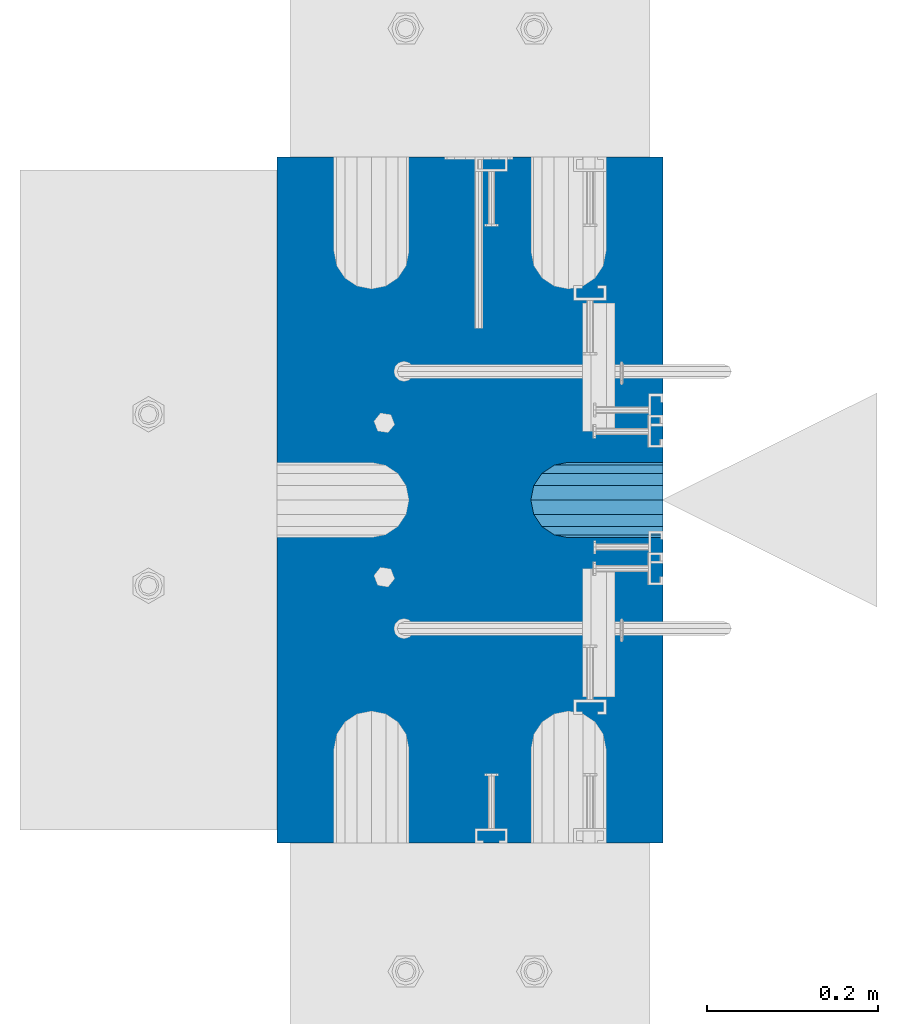
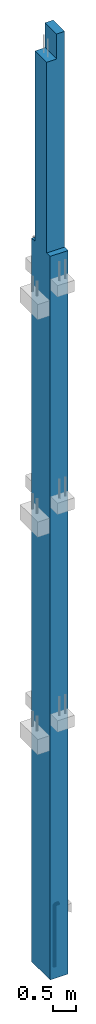
# One storey, part 2 of 41: 1 beam, 1 column, 2 elements without a shape of their own.
"""IFC2X3 building model written with IfcOpenShell, lengths in millimetres."""

from ifc_helpers import new_model, si_unit, frame, origin_with_axes, place, context, subcontext, project, spatial, faceted_brep, material, type_object, element, aggregate, save


model = new_model("IFC2X3")

# Units and contexts
model_context = context("Model", 3, precision=1e-05, world=origin_with_axes())
body_context = subcontext(model_context, "Body", "Model", "MODEL_VIEW")
ifc_project = project(units=[si_unit("LENGTHUNIT", "METRE", prefix="MILLI"), si_unit("AREAUNIT", "SQUARE_METRE"), si_unit("VOLUMEUNIT", "CUBIC_METRE"), si_unit("MASSUNIT", "GRAM", prefix="KILO"), si_unit("TIMEUNIT", "SECOND"), si_unit("PLANEANGLEUNIT", "RADIAN"), si_unit("SOLIDANGLEUNIT", "STERADIAN"), si_unit("THERMODYNAMICTEMPERATUREUNIT", "DEGREE_CELSIUS"), si_unit("LUMINOUSINTENSITYUNIT", "LUMEN")], contexts=[model_context])

# Site, building, storey
site_placement = place(None, frame((-177556.685383467, -198018.589999756, 1290.0), z_axis=(0.0, 0.0, 1.0), x_axis=(0.788225611989142, -0.615386370180835, 0.0)))
site = spatial("IfcSite", under=ifc_project, at=site_placement, CompositionType="ELEMENT")
building_placement = place(site_placement, origin_with_axes())
building = spatial("IfcBuilding", under=site, at=building_placement, Name="Undefined", CompositionType="ELEMENT")
storey_placement = place(building_placement, origin_with_axes())
storey = spatial("IfcBuildingStorey", under=building, at=storey_placement, Name="Undefined", CompositionType="ELEMENT", Elevation=0.0)

# Assemblies, column, beam
assembly_1_placement = place(storey_placement, origin_with_axes())
assembly_1 = element("IfcElementAssembly", 1, at=assembly_1_placement, inside=storey, AssemblyPlace="NOTDEFINED", PredefinedType="REINFORCEMENT_UNIT")
ifc_material_1 = material(Name="CONCRETE/C50/60")
column_type = type_object("IfcColumnType", PredefinedType="NOTDEFINED")
column_placement = place(assembly_1_placement, frame((18096.7856708698, 265349.288407257, -1290.0), z_axis=(-0.788225611989142, -0.615386370180835, 0.0), x_axis=(0.0, 0.0, 1.0)))
column = element("IfcColumn", 2, at=column_placement, type_object=column_type, material=ifc_material_1, context=body_context, shape_type="Brep", body=[
    faceted_brep([(24210.0, -250.000000288157, 225.00000024747), (24210.0, -250.000000288797, -24.9999997523264), (24210.0, 249.99999971097, -24.9999997548875), (24210.0, 249.999999711639, 225.000000244938), (24870.0, -250.000000288797, -24.9999997523264), (24870.0, 249.99999971097, -24.9999997548875), (19160.0, -400.000000288099, 225.000000248256), (19160.0, -400.000000289263, -224.999999751424), (19160.0, -250.000000289321, -224.999999752152), (19160.0, -250.000000288157, 225.00000024747), (0.0, -400.000000329339, 225.000000121712), (0.0, -400.000000330474, -224.999999877968), (0.0, 399.999999670341, 225.000000117609), (0.0, 399.999999669206, -224.999999882071), (19160.0, 399.999999711552, 225.000000244181), (19160.0, 399.999999710388, -224.999999755499), (19160.0, 249.999999711639, 225.000000244938), (19160.0, 249.999999710475, -224.999999754713), (24870.0, -250.000000289321, -224.999999752152), (24870.0, 249.999999710475, -224.999999754713)], [[[0, 1, 2, 3]], [[4, 5, 2, 1]], [[6, 7, 8, 9]], [[10, 11, 7, 6]], [[11, 10, 12, 13]], [[13, 12, 14, 15]], [[16, 17, 15, 14]], [[18, 8, 7, 11, 13, 15, 17, 19]], [[0, 9, 8, 18, 4, 1]], [[16, 14, 12, 10, 6, 9, 0, 3]], [[19, 17, 16, 3, 2, 5]], [[18, 19, 5, 4]]]),
])
assembly_2_placement = place(assembly_1_placement, origin_with_axes())
assembly_2 = element("IfcElementAssembly", 3, at=assembly_2_placement, AssemblyPlace="NOTDEFINED", PredefinedType="RIGID_FRAME")
aggregate(assembly_1, [assembly_2, column])
ifc_material_2 = material(Name="STEEL/NEG_BETON")
beam_type = type_object("IfcBeamType", PredefinedType="NOTDEFINED")
beam_placement = place(assembly_2_placement, frame((18187.4316162484, 265420.057839827, -1290.0), z_axis=(0.615386370178831, -0.788225611990706, 0.0), x_axis=(0.0, 0.0, 1.0)))
beam = element("IfcBeam", 4, at=beam_placement, type_object=beam_type, material=ifc_material_2, context=body_context, shape_type="Brep", body=[
    faceted_brep([(0.0, -43.999999753345, 2.88331648334861e-07), (0.0, -40.6506991838105, -16.8380707357428), (1590.0, -40.6506991838105, -16.8380707357428), (1589.99999999999, -43.999999753345, 2.88331648334861e-07), (0.0, -31.1126981254783, -31.1126980838017), (1590.0, -31.1126981254783, -31.1126980838017), (0.0, -16.8380707773322, -40.6506991419883), (1590.0, -16.8380707773322, -40.6506991419883), (0.0, 2.46742274612188e-07, -43.9999997114064), (1590.0, 2.46742274612188e-07, -43.9999997114064), (0.0, 16.8380712707876, -40.6506991418137), (1590.0, 16.8380712707876, -40.6506991418137), (0.0, 31.1126986189047, -31.1126980834524), (1590.0, 31.1126986189047, -31.1126980834524), (0.0, 40.6506996771204, -16.8380707352771), (1590.0, 40.6506996771204, -16.8380707352771), (0.0, 44.0000002465677, 2.88768205791712e-07), (1590.0, 44.0000002465677, 2.88768205791712e-07), (0.0, 40.6506996770622, 16.8380713128427), (1590.0, 40.6506996770622, 16.8380713128427), (0.0, 31.1126986187301, 31.1126986609306), (1590.0, 31.1126986187301, 31.1126986609306), (0.0, 16.8380712705839, 40.6506997191464), (1590.0, 16.8380712705839, 40.6506997191464), (0.0, 2.46509443968534e-07, 44.0000002885354), (1590.0, 2.46509443968534e-07, 44.0000002885354), (0.0, -16.8380707775359, 40.6506997189426), (1590.0, -16.8380707775359, 40.6506997189426), (0.0, -31.1126981256821, 31.1126986605814), (1590.0, -31.1126981256821, 31.1126986605814), (0.0, -40.6506991838978, 16.838071312377), (1590.0, -40.6506991838978, 16.838071312377), (4.47878846898675e-07, -40.0000000634464, 0.0), (4.47878846898675e-07, -36.9551813638827, 15.3073372946019), (1590.0, -36.9551810538396, 15.3073375829845), (1589.99999999999, -39.999999753345, 2.88360752165318e-07), (4.47937054559588e-07, -28.2842713108694, 28.284271247463), (1590.0, -28.2842710008845, 28.2842715359002), (4.4800981413573e-07, -15.3073373580119, 36.9551813004509), (1590.0, -15.3073370480561, 36.9551815889135), (4.48068021796644e-07, -6.34463503956795e-08, 40.0), (1590.0, 2.46538547798991e-07, 40.0000002885645), (4.48140781372786e-07, 15.3073372311774, 36.9551813004509), (1590.0, 15.3073375411332, 36.9551815890882), (4.48213540948927e-07, 28.2842711840058, 28.284271247463), (1590.0, 28.2842714939907, 28.2842715361621), (4.48271748609841e-07, 36.95518123699, 15.3073372946019), (1590.0, 36.9551815469749, 15.3073375833046), (4.48286300525069e-07, 39.9999999365536, 0.0), (1590.0, 40.0000002465677, 2.88768205791712e-07), (4.48271748609841e-07, 36.95518123699, -15.3073372946019), (1590.0, 36.9551815470913, -15.3073370058555), (4.48213540948927e-07, 28.2842711840058, -28.284271247463), (1590.0, 28.2842714941071, -28.2842709587712), (4.48140781372786e-07, 15.3073372311774, -36.9551813004509), (1590.0, 15.3073375413369, -36.9551810117846), (4.48068021796644e-07, -6.34463503956795e-08, -40.0), (1590.0, 2.46742274612188e-07, -39.9999997114064), (4.4800981413573e-07, -15.3073373580119, -36.9551813004509), (1590.0, -15.3073370479106, -36.9551810119592), (4.47937054559588e-07, -28.2842713108694, -28.284271247463), (1590.0, -28.284271000739, -28.2842709590332), (4.47878846898675e-07, -36.9551813638827, -15.3073372946019), (1590.0, -36.9551810537523, -15.3073370062048), (1591.55291427061, -44.204444795876, 2.88884621113539e-07), (1592.41977704577, -40.969268875866, 16.83807131293), (1594.88839337186, -31.7562673225475, 31.1126986611343), (1598.5829387913, -17.9680361063511, 40.6506997194665), (1602.94095225512, -1.70370843930868, 44.0000002890592), (1607.29896571893, 14.5606192276464, 40.650699719612), (1610.99351113838, 28.3488504439301, 31.1126986614254), (1613.46212746447, 37.5618519973068, 16.8380713133374), (1614.32899023963, 40.7970279174624, 2.89292074739933e-07), (1613.46212746447, 37.5618519973941, -16.8380707347824), (1610.99351113838, 28.3488504441048, -31.1126980829576), (1607.29896571893, 14.5606192278792, -40.650699141348), (1602.94095225512, -1.70370843910496, -43.9999997109117), (1598.5829387913, -17.9680361061473, -40.6506991414644), (1594.88839337186, -31.7562673223438, -31.1126980832487), (1592.41977704577, -40.9692688757787, -16.8380707351898), (1613.29371405922, 36.9333246122987, 2.89292074739933e-07), (1612.50565699089, 33.9922555939993, 15.3073375838285), (1610.26146033081, 25.6167996363656, 28.2842715366569), (1606.90278267677, 13.082043985225, 36.9551815895829), (1602.94095225512, -1.70370843933779, 40.0000002890883), (1598.97912183347, -16.4894608639006, 36.9551815894083), (1595.62044417943, -29.024216514983, 28.2842715363658), (1593.37624751934, -37.3996724725293, 15.3073375835083), (1592.58819045102, -40.3407414907415, 2.88913724943995e-07), (1593.37624751934, -37.3996724724711, -15.30733700571), (1595.62044417943, -29.0242165148375, -28.2842709585093), (1598.97912183347, -16.489460863726, -36.9551810114353), (1602.94095225512, -1.70370843910496, -39.9999997108825), (1606.90278267677, 13.0820439854288, -36.9551810112898), (1610.26146033081, 25.6167996365111, -28.2842709582183), (1612.50565699089, 33.9922555940866, -15.3073370053316), (1630.55634918609, 20.2456576060504, 31.1126986613672), (1635.32534971523, 28.5058088238875, 16.8380713132792), (1623.41903551202, 7.88346769296913, 40.6506997195829), (1614.99999999998, -6.6987295645813, 44.0000002890592), (1606.58096448795, -21.2809268221026, 40.6506997194665), (1599.44365081388, -33.6431167351257, 31.1126986611052), (1594.67465028474, -41.9032679528755, 16.83807131293), (1592.99999999999, -44.8038473309425, 2.88884621113539e-07), (1594.67465028474, -41.9032679528173, -16.8380707351898), (1599.44365081388, -33.6431167349801, -31.1126980832778), (1606.58096448795, -21.2809268218698, -40.6506991414935), (1614.99999999998, -6.69872956431936, -43.9999997108825), (1623.41903551202, 7.88346769317286, -40.6506991413771), (1630.55634918609, 20.245657606225, -31.1126980830159), (1635.32534971523, 28.5058088239748, -16.8380707348406), (1636.99999999998, 31.4063882019836, 2.89204763248563e-07), (1633.47759065021, 25.3053962432023, -15.307337005419), (1634.99999999998, 27.9422865869128, 2.89262970909476e-07), (1629.14213562371, 17.7961678634456, -28.2842709582474), (1622.65366864729, 6.55781339702662, -36.9551810113189), (1614.99999999998, -6.69872956431936, -39.9999997109117), (1607.34633135268, -19.9552725257818, -36.9551810114644), (1600.85786437626, -31.1936269922007, -28.2842709585384), (1596.52240934976, -38.7028553720447, -15.30733700571), (1594.99999999999, -41.3397457158135, 2.88884621113539e-07), (1596.52240934976, -38.7028553721029, 15.3073375835083), (1600.85786437626, -31.1936269923463, 28.2842715363658), (1607.34633135268, -19.9552725259855, 36.9551815894083), (1614.99999999998, -6.6987295645522, 40.0000002890592), (1622.65366864729, 6.5578133968811, 36.9551815895829), (1629.14213562371, 17.796167863271, 28.2842715366278), (1633.47759065021, 25.305396243115, 15.3073375837994), (1647.35533905931, 7.35533930556267, 31.1126986613381), (1654.09972428659, 14.0997245328326, 16.8380713131919), (1637.26165326253, -2.73834649124183, 40.6506997195538), (1625.35533905931, -14.6446606944664, 44.000000289001), (1613.4490248561, -26.5509748976619, 40.6506997194374), (1603.35533905931, -36.6446606944373, 31.1126986610761), (1596.61095383203, -43.3890459216491, 16.83807131293), (1594.24264068711, -45.7573590665124, 2.88855517283082e-07), (1596.61095383203, -43.3890459215909, -16.8380707352189), (1603.35533905931, -36.6446606942627, -31.1126980833069), (1613.4490248561, -26.5509748974582, -40.6506991415517), (1625.35533905931, -14.6446606942336, -43.9999997109699), (1637.26165326253, -2.7383464910381, -40.6506991414062), (1647.35533905931, 7.35533930567908, -31.1126980831032), (1654.09972428659, 14.099724532949, -16.8380707348988), (1656.46803743151, 16.4680376778415, 2.89175659418106e-07), (1651.48659835683, 11.4865986031655, -15.3073370054772), (1653.63961030677, 13.6396105530439, 2.89146555587649e-07), (1645.35533905931, 5.35533930567908, -28.2842709583347), (1636.17926106223, -3.82073869134183, -36.9551810113771), (1625.35533905931, -14.6446606942336, -39.9999997109699), (1614.53141705639, -25.4685826971836, -36.9551810114644), (1605.35533905931, -34.6446606942627, -28.2842709585675), (1599.22407976179, -40.7759199918073, -15.3073370057391), (1597.07106781185, -42.9289319418021, 2.88826413452625e-07), (1599.22407976179, -40.7759199918946, 15.3073375834792), (1605.35533905931, -34.6446606944082, 28.284271536395), (1614.53141705639, -25.4685826973582, 36.9551815894083), (1625.35533905931, -14.6446606944373, 40.000000289001), (1636.17926106223, -3.82073869154556, 36.9551815894956), (1645.35533905931, 5.35533930556267, 28.2842715365696), (1651.48659835683, 11.4865986031364, 15.3073375837412), (1660.24565735981, -9.44365056764218, 31.1126986612508), (1668.50580857761, -4.6746500384761, 16.8380713131337), (1647.88346744676, -16.5809642417589, 40.6506997194665), (1633.3012701892, -24.9999997537816, 44.0000002889428), (1618.71907293164, -33.4190352658043, 40.6506997193792), (1606.35688301859, -40.5563489398628, 31.112698661047), (1598.09673180079, -45.3253494689416, 16.8380713129009), (1595.19615242269, -46.9999997536361, 2.88855517283082e-07), (1598.09673180079, -45.3253494688834, -16.8380707352189), (1606.35688301859, -40.5563489396882, -31.112698083336), (1618.71907293164, -33.4190352655714, -40.6506991415517), (1633.3012701892, -24.9999997535488, -43.9999997110281), (1647.88346744676, -16.5809642415552, -40.6506991414644), (1660.24565735981, -9.44365056749666, -31.1126980831614), (1668.50580857761, -4.67465003841789, -16.8380707349861), (1671.40638795571, -2.99999975369428, 2.89088347926736e-07), (1665.30539599684, -6.52240910343244, -15.3073370055354), (1667.94228634057, -4.99999975372339, 2.89030140265822e-07), (1657.79616761703, -10.8578641298518, -28.2842709583929), (1646.55781315062, -17.3463311062951, -36.9551810114644), (1633.3012701892, -24.9999997535488, -39.999999710999), (1620.04472722778, -32.6536684008606, -36.9551810115227), (1608.80637276137, -39.142135377333, -28.2842709585675), (1601.29714438156, -43.4775904038397, -15.30733700571), (1598.66025403783, -44.9999997536652, 2.88826413452625e-07), (1601.29714438156, -43.4775904038979, 15.3073375834501), (1608.80637276137, -39.1421353774786, 28.2842715363076), (1620.04472722778, -32.6536684010644, 36.9551815893792), (1633.3012701892, -24.9999997537816, 40.0000002889428), (1646.55781315062, -17.3463311064697, 36.9551815894374), (1657.79616761703, -10.8578641300264, 28.2842715364823), (1665.30539599684, -6.52240910349065, 15.3073375836248), (1668.34885019768, -29.006488615385, 31.1126986611052), (1677.56185175105, -26.5378722892492, 16.8380713130173), (1654.56061898146, -32.7010340348643, 40.6506997193792), (1638.29629131443, -37.0590474986238, 44.0000002888846), (1622.0319636474, -41.4170609624416, 40.6506997193792), (1608.24373243118, -45.1116063818336, 31.1126986610761), (1599.03073087781, -47.5802227078821, 16.83807131293), (1595.79555495772, -48.4470854829997, 2.88855517283082e-07), (1599.03073087781, -47.5802227078239, -16.8380707351898), (1608.24373243118, -45.111606381688, -31.112698083336), (1622.0319636474, -41.4170609622379, -40.6506991415808), (1638.29629131443, -37.0590474984201, -43.9999997110572), (1654.56061898146, -32.7010340346314, -40.6506991415808), (1668.34885019768, -29.0064886152395, -31.1126980832778), (1677.56185175105, -26.5378722891619, -16.8380707351025), (1680.79702767114, -25.6710095140443, 2.88913724943995e-07), (1673.99225534772, -27.4943427627441, -15.3073370056518), (1676.93332436598, -26.7062856944685, 2.88942828774452e-07), (1665.61679939011, -29.7385394227749, -28.2842709585093), (1653.082043739, -33.0972170768073, -36.9551810115518), (1638.29629131443, -37.0590474984201, -39.9999997110572), (1623.51053888986, -41.020877920062, -36.9551810115518), (1610.97578323875, -44.3795555741235, -28.2842709585675), (1602.60032728114, -46.6237522342417, -15.3073370057391), (1599.65925826287, -47.4118093026336, 2.88826413452625e-07), (1602.60032728114, -46.623752234329, 15.3073375834501), (1610.97578323875, -44.379555574269, 28.2842715363076), (1623.51053888986, -41.0208779202658, 36.955181589321), (1638.29629131443, -37.0590474986238, 40.0000002889137), (1653.082043739, -33.0972170769819, 36.9551815893501), (1665.61679939011, -29.7385394229495, 28.2842715363658), (1673.99225534772, -27.4943427628314, 15.3073375835083), (1608.88730162777, -49.9999997535779, -31.1126980833942), (1599.34930056949, -49.999999753607, -16.838070735248), (1623.16192897591, -49.9999997535488, -40.6506991416682), (1639.99999999997, -49.9999997535488, -43.9999997111445), (1656.83807102403, -49.9999997535488, -40.6506991416682), (1671.11269837217, -49.9999997535779, -31.1126980833942), (1680.65069943045, -49.999999753607, -16.838070735248), (1683.99999999996, -49.9999997536361, 2.88826413452625e-07), (1680.65069943045, -49.9999997536943, 16.8380713128718), (1671.11269837217, -49.9999997537234, 31.1126986609888), (1656.83807102403, -49.9999997537525, 40.650699719321), (1639.99999999997, -49.9999997537816, 44.0000002887973), (1623.16192897591, -49.9999997537525, 40.650699719321), (1608.88730162777, -49.9999997536943, 31.112698661047), (1599.34930056949, -49.9999997536943, 16.8380713128718), (1596.0, -49.9999997536361, 2.88826413452625e-07), (1676.95518130041, -49.9999997535779, -15.3073370057391), (1679.99999999996, -49.9999997536361, 2.88826413452625e-07), (1668.28427124742, -49.9999997535488, -28.2842709585966), (1655.30733729457, -49.9999997535488, -36.9551810116391), (1639.99999999997, -49.9999997535197, -39.9999997111445), (1624.69266270537, -49.9999997535488, -36.9551810116391), (1611.71572875252, -49.9999997535488, -28.2842709585966), (1603.04481869953, -49.9999997535779, -15.3073370057391), (1600.0, -49.9999997536361, 2.88826413452625e-07), (1603.04481869953, -49.9999997536943, 15.307337583421), (1611.71572875252, -49.9999997537234, 28.2842715362785), (1624.69266270537, -49.9999997537525, 36.9551815892628), (1639.99999999997, -49.9999997537525, 40.0000002888264), (1655.30733729457, -49.9999997537525, 36.9551815892628), (1668.28427124742, -49.9999997537234, 28.2842715362785), (1676.95518130041, -49.9999997536943, 15.307337583421), (1599.3493005695, -109.999999753578, -16.8380707355391), (1596.0, -109.999999753607, 2.88506271317601e-07), (1608.88730162779, -109.999999753549, -31.1126980836852), (1623.16192897594, -109.999999753491, -40.6506991419592), (1640.0, -109.999999753491, -43.9999997114646), (1656.83807102406, -109.999999753491, -40.6506991419592), (1671.11269837221, -109.999999753549, -31.1126980836852), (1680.6506994305, -109.999999753578, -16.8380707355391), (1684.0, -109.999999753607, 2.88506271317601e-07), (1680.6506994305, -109.999999753636, 16.8380713125807), (1671.11269837221, -109.999999753694, 31.1126986607269), (1656.83807102406, -109.999999753723, 40.6506997190008), (1640.0, -109.999999753723, 44.0000002885063), (1623.16192897594, -109.999999753723, 40.6506997190008), (1608.88730162779, -109.999999753694, 31.1126986607269), (1599.3493005695, -109.999999753636, 16.8380713125807), (1603.04481869955, -109.999999753636, 15.3073375831009), (1600.0, -109.999999753607, 2.88506271317601e-07), (1611.71572875254, -109.999999753665, 28.2842715359584), (1624.6926627054, -109.999999753665, 36.9551815889718), (1640.0, -109.999999753694, 40.0000002884772), (1655.3073372946, -109.999999753665, 36.9551815889718), (1668.28427124746, -109.999999753665, 28.2842715359584), (1676.95518130045, -109.999999753636, 15.3073375831009), (1680.0, -109.999999753607, 2.88506271317601e-07), (1676.95518130045, -109.999999753578, -15.3073370060883), (1668.28427124746, -109.999999753549, -28.2842709589167), (1655.3073372946, -109.99999975352, -36.955181011901), (1640.0, -109.99999975352, -39.9999997114646), (1624.6926627054, -109.99999975352, -36.955181011901), (1611.71572875254, -109.999999753549, -28.2842709589167), (1603.04481869955, -109.999999753578, -15.3073370060883)], [[[0, 1, 2, 3]], [[1, 4, 5, 2]], [[4, 6, 7, 5]], [[6, 8, 9, 7]], [[8, 10, 11, 9]], [[10, 12, 13, 11]], [[12, 14, 15, 13]], [[14, 16, 17, 15]], [[16, 18, 19, 17]], [[18, 20, 21, 19]], [[20, 22, 23, 21]], [[22, 24, 25, 23]], [[24, 26, 27, 25]], [[26, 28, 29, 27]], [[28, 30, 31, 29]], [[30, 0, 3, 31]], [[32, 33, 34, 35]], [[33, 36, 37, 34]], [[36, 38, 39, 37]], [[38, 40, 41, 39]], [[40, 42, 43, 41]], [[42, 44, 45, 43]], [[44, 46, 47, 45]], [[46, 48, 49, 47]], [[48, 50, 51, 49]], [[50, 52, 53, 51]], [[52, 54, 55, 53]], [[54, 56, 57, 55]], [[56, 58, 59, 57]], [[58, 60, 61, 59]], [[60, 62, 63, 61]], [[62, 32, 35, 63]], [[30, 28, 26, 24, 22, 20, 18, 16, 14, 12, 10, 8, 6, 4, 1, 0], [62, 60, 58, 56, 54, 52, 50, 48, 46, 44, 42, 40, 38, 36, 33, 32]], [[31, 3, 64, 65]], [[29, 31, 65, 66]], [[27, 29, 66, 67]], [[25, 27, 67, 68]], [[23, 25, 68, 69]], [[21, 23, 69, 70]], [[19, 21, 70, 71]], [[17, 19, 71, 72]], [[15, 17, 72, 73]], [[13, 15, 73, 74]], [[11, 13, 74, 75]], [[9, 11, 75, 76]], [[7, 9, 76, 77]], [[5, 7, 77, 78]], [[2, 5, 78, 79]], [[3, 2, 79, 64]], [[47, 49, 80, 81]], [[45, 47, 81, 82]], [[43, 45, 82, 83]], [[41, 43, 83, 84]], [[39, 41, 84, 85]], [[37, 39, 85, 86]], [[34, 37, 86, 87]], [[35, 34, 87, 88]], [[63, 35, 88, 89]], [[61, 63, 89, 90]], [[59, 61, 90, 91]], [[57, 59, 91, 92]], [[55, 57, 92, 93]], [[53, 55, 93, 94]], [[51, 53, 94, 95]], [[49, 51, 95, 80]], [[70, 96, 97, 71]], [[69, 98, 96, 70]], [[68, 99, 98, 69]], [[67, 100, 99, 68]], [[66, 101, 100, 67]], [[65, 102, 101, 66]], [[64, 103, 102, 65]], [[79, 104, 103, 64]], [[78, 105, 104, 79]], [[77, 106, 105, 78]], [[76, 107, 106, 77]], [[75, 108, 107, 76]], [[74, 109, 108, 75]], [[73, 110, 109, 74]], [[72, 111, 110, 73]], [[71, 97, 111, 72]], [[95, 112, 113, 80]], [[94, 114, 112, 95]], [[93, 115, 114, 94]], [[92, 116, 115, 93]], [[91, 117, 116, 92]], [[90, 118, 117, 91]], [[89, 119, 118, 90]], [[88, 120, 119, 89]], [[87, 121, 120, 88]], [[86, 122, 121, 87]], [[85, 123, 122, 86]], [[84, 124, 123, 85]], [[83, 125, 124, 84]], [[82, 126, 125, 83]], [[81, 127, 126, 82]], [[80, 113, 127, 81]], [[96, 128, 129, 97]], [[98, 130, 128, 96]], [[99, 131, 130, 98]], [[100, 132, 131, 99]], [[101, 133, 132, 100]], [[102, 134, 133, 101]], [[103, 135, 134, 102]], [[104, 136, 135, 103]], [[105, 137, 136, 104]], [[106, 138, 137, 105]], [[107, 139, 138, 106]], [[108, 140, 139, 107]], [[109, 141, 140, 108]], [[110, 142, 141, 109]], [[111, 143, 142, 110]], [[97, 129, 143, 111]], [[112, 144, 145, 113]], [[114, 146, 144, 112]], [[115, 147, 146, 114]], [[116, 148, 147, 115]], [[117, 149, 148, 116]], [[118, 150, 149, 117]], [[119, 151, 150, 118]], [[120, 152, 151, 119]], [[121, 153, 152, 120]], [[122, 154, 153, 121]], [[123, 155, 154, 122]], [[124, 156, 155, 123]], [[125, 157, 156, 124]], [[126, 158, 157, 125]], [[127, 159, 158, 126]], [[113, 145, 159, 127]], [[128, 160, 161, 129]], [[130, 162, 160, 128]], [[131, 163, 162, 130]], [[132, 164, 163, 131]], [[133, 165, 164, 132]], [[134, 166, 165, 133]], [[135, 167, 166, 134]], [[136, 168, 167, 135]], [[137, 169, 168, 136]], [[138, 170, 169, 137]], [[139, 171, 170, 138]], [[140, 172, 171, 139]], [[141, 173, 172, 140]], [[142, 174, 173, 141]], [[143, 175, 174, 142]], [[129, 161, 175, 143]], [[144, 176, 177, 145]], [[146, 178, 176, 144]], [[147, 179, 178, 146]], [[148, 180, 179, 147]], [[149, 181, 180, 148]], [[150, 182, 181, 149]], [[151, 183, 182, 150]], [[152, 184, 183, 151]], [[153, 185, 184, 152]], [[154, 186, 185, 153]], [[155, 187, 186, 154]], [[156, 188, 187, 155]], [[157, 189, 188, 156]], [[158, 190, 189, 157]], [[159, 191, 190, 158]], [[145, 177, 191, 159]], [[160, 192, 193, 161]], [[162, 194, 192, 160]], [[163, 195, 194, 162]], [[164, 196, 195, 163]], [[165, 197, 196, 164]], [[166, 198, 197, 165]], [[167, 199, 198, 166]], [[168, 200, 199, 167]], [[169, 201, 200, 168]], [[170, 202, 201, 169]], [[171, 203, 202, 170]], [[172, 204, 203, 171]], [[173, 205, 204, 172]], [[174, 206, 205, 173]], [[175, 207, 206, 174]], [[161, 193, 207, 175]], [[176, 208, 209, 177]], [[178, 210, 208, 176]], [[179, 211, 210, 178]], [[180, 212, 211, 179]], [[181, 213, 212, 180]], [[182, 214, 213, 181]], [[183, 215, 214, 182]], [[184, 216, 215, 183]], [[185, 217, 216, 184]], [[186, 218, 217, 185]], [[187, 219, 218, 186]], [[188, 220, 219, 187]], [[189, 221, 220, 188]], [[190, 222, 221, 189]], [[191, 223, 222, 190]], [[177, 209, 223, 191]], [[201, 224, 225, 200]], [[202, 226, 224, 201]], [[203, 227, 226, 202]], [[204, 228, 227, 203]], [[205, 229, 228, 204]], [[206, 230, 229, 205]], [[207, 231, 230, 206]], [[193, 232, 231, 207]], [[192, 233, 232, 193]], [[194, 234, 233, 192]], [[195, 235, 234, 194]], [[196, 236, 235, 195]], [[197, 237, 236, 196]], [[198, 238, 237, 197]], [[199, 239, 238, 198]], [[200, 225, 239, 199]], [[208, 240, 241, 209]], [[210, 242, 240, 208]], [[211, 243, 242, 210]], [[212, 244, 243, 211]], [[213, 245, 244, 212]], [[214, 246, 245, 213]], [[215, 247, 246, 214]], [[216, 248, 247, 215]], [[217, 249, 248, 216]], [[218, 250, 249, 217]], [[219, 251, 250, 218]], [[220, 252, 251, 219]], [[221, 253, 252, 220]], [[222, 254, 253, 221]], [[223, 255, 254, 222]], [[209, 241, 255, 223]], [[239, 225, 256, 257]], [[225, 224, 258, 256]], [[224, 226, 259, 258]], [[226, 227, 260, 259]], [[227, 228, 261, 260]], [[228, 229, 262, 261]], [[229, 230, 263, 262]], [[230, 231, 264, 263]], [[231, 232, 265, 264]], [[232, 233, 266, 265]], [[233, 234, 267, 266]], [[234, 235, 268, 267]], [[235, 236, 269, 268]], [[236, 237, 270, 269]], [[237, 238, 271, 270]], [[238, 239, 257, 271]], [[248, 249, 272, 273]], [[249, 250, 274, 272]], [[250, 251, 275, 274]], [[251, 252, 276, 275]], [[252, 253, 277, 276]], [[253, 254, 278, 277]], [[254, 255, 279, 278]], [[255, 241, 280, 279]], [[241, 240, 281, 280]], [[240, 242, 282, 281]], [[242, 243, 283, 282]], [[243, 244, 284, 283]], [[244, 245, 285, 284]], [[245, 246, 286, 285]], [[246, 247, 287, 286]], [[247, 248, 273, 287]], [[258, 259, 260, 261, 262, 263, 264, 265, 266, 267, 268, 269, 270, 271, 257, 256], [274, 275, 276, 277, 278, 279, 280, 281, 282, 283, 284, 285, 286, 287, 273, 272]]]),
])
aggregate(assembly_2, [beam])

save(model, "model.ifc")
